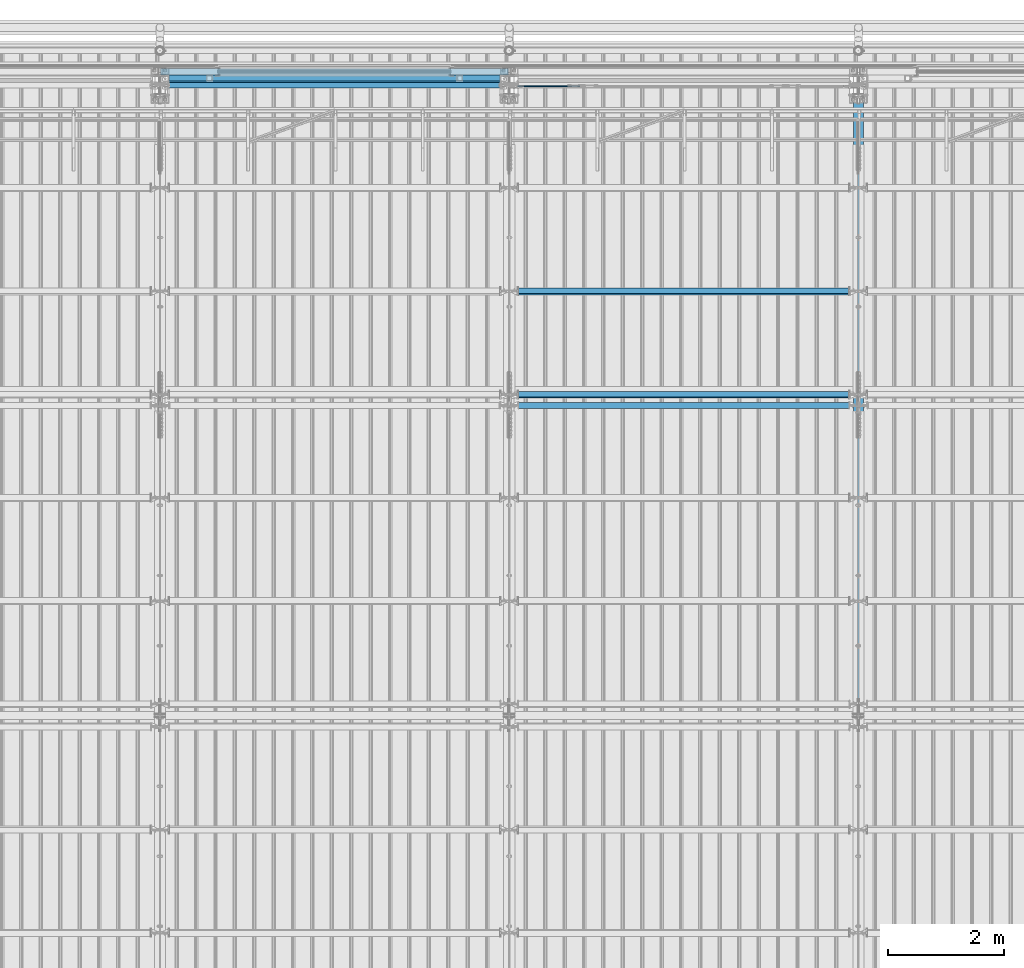
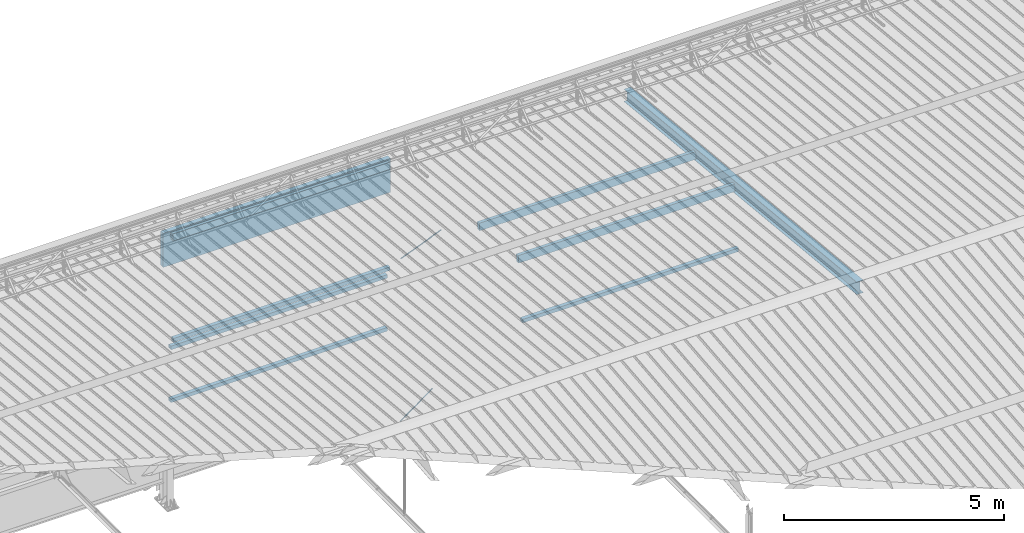
# One storey, part 268 of 709: 9 beams, 2 members, 2 openings, 11 elements without a shape of their own.
"""IFC4 building model written with IfcOpenShell, lengths in millimetres."""

from ifc_helpers import new_model, si_unit, direction, frame, origin_with_axes, place, context, subcontext, project, spatial, line, indexed_curve, outline, extrude, polygons, material, element, aggregate, save


model = new_model("IFC4")

# Units and contexts
model_context = context("Model", 3, precision=0.2, world=origin_with_axes(), true_north=direction((0.0, 1.0)))
body_context = subcontext(model_context, "Body", "Model", "MODEL_VIEW")
reference_context = subcontext(model_context, "Reference", "Model", "MODEL_VIEW")
ifc_project = project(units=[si_unit("LENGTHUNIT", "METRE", prefix="MILLI"), si_unit("AREAUNIT", "SQUARE_METRE"), si_unit("VOLUMEUNIT", "CUBIC_METRE"), si_unit("MASSUNIT", "GRAM", prefix="KILO"), si_unit("TIMEUNIT", "SECOND"), si_unit("PLANEANGLEUNIT", "RADIAN"), si_unit("SOLIDANGLEUNIT", "STERADIAN"), si_unit("THERMODYNAMICTEMPERATUREUNIT", "DEGREE_CELSIUS"), si_unit("LUMINOUSINTENSITYUNIT", "LUMEN")], contexts=[model_context])

# Site, building, storey
site_placement = place(None, origin_with_axes())
site = spatial("IfcSite", under=ifc_project, at=site_placement, CompositionType="ELEMENT")
building_placement = place(site_placement, origin_with_axes())
building = spatial("IfcBuilding", under=site, at=building_placement, Name="Undefined", CompositionType="ELEMENT")
storey_placement = place(building_placement, origin_with_axes())
storey = spatial("IfcBuildingStorey", under=building, at=storey_placement, Name="Undefined", CompositionType="ELEMENT", Elevation=0.0)

# Assembly, beam
assembly_1_placement = place(storey_placement, frame((28000.0, 21654.0, 7089.70002), z_axis=(-1.0, 0.0, 0.0), x_axis=(0.0, -0.9950371902, 0.099503719)))
assembly_1 = element("IfcElementAssembly", 1, at=assembly_1_placement, inside=storey)
ifc_material_1 = material(Name="C355-5", Category="STEEL")
beam_1_placement = place(assembly_1_placement, origin_with_axes())
beam_1 = element("IfcBeam", 2, at=beam_1_placement, material=ifc_material_1, ObjectType="432", context=body_context, shape_type="Tessellation", body=[
    polygons([(3.80474, -173.0, -87.0), (4.70474, -164.0, -87.0), (10665.6128, -164.0, -87.0), (10664.7128, -173.0, -87.0), (4.70474, -164.0, -3.0), (10665.6128, -164.0, -3.0), (37.50474, 164.0, -3.0), (10698.4128, 164.0, -3.0), (37.50474, 164.0, -87.0), (10698.4128, 164.0, -87.0), (38.40474, 173.0, -87.0), (10699.3128, 173.0, -87.0), (38.40474, 173.0, 87.0), (10699.3128, 173.0, 87.0), (37.50474, 164.0, 87.0), (10698.4128, 164.0, 87.0), (37.50474, 164.0, 3.0), (10698.4128, 164.0, 3.0), (4.70474, -164.0, 3.0), (10665.6128, -164.0, 3.0), (4.70474, -164.0, 87.0), (10665.6128, -164.0, 87.0), (3.80474, -173.0, 87.0), (10664.7128, -173.0, 87.0)], [[[1, 2, 3, 4]], [[2, 5, 6, 3]], [[5, 7, 8, 6]], [[7, 9, 10, 8]], [[9, 11, 12, 10]], [[11, 13, 14, 12]], [[13, 15, 16, 14]], [[15, 17, 18, 16]], [[17, 19, 20, 18]], [[19, 21, 22, 20]], [[21, 23, 24, 22]], [[23, 1, 4, 24]], [[6, 8, 10, 12, 14, 16, 18, 20, 22, 24, 4, 3]], [[23, 21, 19, 17, 15, 13, 11, 9, 7, 5, 2, 1]]], closed=True),
])
aggregate(assembly_1, [beam_1])

# Assembly, member, voiding feature
assembly_2_placement = place(storey_placement, frame((23129.07626, 21811.0, 672.76012), z_axis=(0.0, 1.0, 0.0), x_axis=(-0.8064830392, 0.0, -0.5912572261)))
assembly_2 = element("IfcElementAssembly", 3, at=assembly_2_placement, inside=storey)
member_1_placement = place(assembly_2_placement, origin_with_axes())
member_1 = element("IfcMember", 4, at=member_1_placement, material=ifc_material_1, ObjectType="548", context=body_context, shape_type="Tessellation", body=[
    polygons([(1225.82155, -5.0, 8.66025), (1225.82155, -7.07107, 7.07107), (1225.82155, -8.66025, 5.0), (1225.82155, -9.65926, 2.58819), (1225.82155, -10.0, 0.0), (1225.82155, -9.65926, -2.58819), (1225.82155, -8.66025, -5.0), (1225.82155, -7.07107, -7.07107), (1225.82155, -5.0, -8.66025), (1225.82155, -2.58819, -9.65926), (1225.82155, 0.0, -10.0), (1225.82155, 2.58819, -9.65926), (1225.82155, 5.0, -8.66025), (1225.82155, 7.07107, -7.07107), (1225.82155, 8.66025, -5.0), (1225.82155, 9.65926, -2.58819), (1225.82155, 10.0, 0.0), (1225.82155, 9.65926, 2.58819), (1225.82155, 8.66025, 5.0), (1225.82155, 7.07107, 7.07107), (1225.82155, 5.0, 8.66025), (1225.82155, 2.58819, 9.65926), (1225.82155, 0.0, 10.0), (1225.82155, -2.58819, 9.65926), (190.0, 10.0, 0.0), (190.0, 9.65926, 2.58819), (190.0, 8.66025, 5.0), (190.0, 7.07107, 7.07107), (190.0, 5.0, 8.66025), (190.0, 2.58819, 9.65926), (190.0, 0.0, 10.0), (190.0, -2.58819, 9.65926), (190.0, -5.0, 8.66025), (190.0, -7.07107, 7.07107), (190.0, -8.66025, 5.0), (190.0, -9.65926, 2.58819), (190.0, -10.0, 0.0), (190.0, -9.65926, -2.58819), (190.0, -8.66025, -5.0), (190.0, -7.07107, -7.07107), (190.0, -5.0, -8.66025), (190.0, -2.58819, -9.65926), (190.0, 0.0, -10.0), (190.0, 2.58819, -9.65926), (190.0, 5.0, -8.66025), (190.0, 7.07107, -7.07107), (190.0, 8.66025, -5.0), (190.0, 9.65926, -2.58819), (10.0, 7.36122, 4.25), (190.0, 7.36122, 4.25), (190.0, 8.21037, 2.19996), (10.0, 8.21037, 2.19996), (10.0, 6.01041, 6.01041), (190.0, 6.01041, 6.01041), (10.0, 4.25, 7.36122), (190.0, 4.25, 7.36122), (10.0, 2.19996, 8.21037), (190.0, 2.19996, 8.21037), (10.0, 0.0, 8.5), (190.0, 0.0, 8.5), (10.0, -2.19996, 8.21037), (190.0, -2.19996, 8.21037), (10.0, -4.25, 7.36122), (190.0, -4.25, 7.36122), (10.0, -6.01041, 6.01041), (190.0, -6.01041, 6.01041), (10.0, -7.36122, 4.25), (190.0, -7.36122, 4.25), (10.0, -8.21037, 2.19996), (190.0, -8.21037, 2.19996), (10.0, -8.5, 0.0), (190.0, -8.5, 0.0), (10.0, -8.21037, -2.19996), (190.0, -8.21037, -2.19996), (10.0, -7.36122, -4.25), (190.0, -7.36122, -4.25), (10.0, -6.01041, -6.01041), (190.0, -6.01041, -6.01041), (10.0, -4.25, -7.36122), (190.0, -4.25, -7.36122), (10.0, -2.19996, -8.21037), (190.0, -2.19996, -8.21037), (10.0, 0.0, -8.5), (190.0, 0.0, -8.5), (10.0, 2.19996, -8.21037), (190.0, 2.19996, -8.21037), (10.0, 4.25, -7.36122), (190.0, 4.25, -7.36122), (10.0, 6.01041, -6.01041), (190.0, 6.01041, -6.01041), (10.0, 7.36122, -4.25), (190.0, 7.36122, -4.25), (10.0, 8.21037, -2.19996), (190.0, 8.21037, -2.19996), (10.0, 8.5, 0.0), (190.0, 8.5, 0.0)], [[[1, 2, 3, 4, 5, 6, 7, 8, 9, 10, 11, 12, 13, 14, 15, 16, 17, 18, 19, 20, 21, 22, 23, 24]], [[18, 17, 25, 26]], [[19, 18, 26, 27]], [[20, 19, 27, 28]], [[21, 20, 28, 29]], [[22, 21, 29, 30]], [[23, 22, 30, 31]], [[24, 23, 31, 32]], [[1, 24, 32, 33]], [[2, 1, 33, 34]], [[3, 2, 34, 35]], [[4, 3, 35, 36]], [[5, 4, 36, 37]], [[6, 5, 37, 38]], [[7, 6, 38, 39]], [[8, 7, 39, 40]], [[9, 8, 40, 41]], [[10, 9, 41, 42]], [[11, 10, 42, 43]], [[12, 11, 43, 44]], [[13, 12, 44, 45]], [[14, 13, 45, 46]], [[15, 14, 46, 47]], [[16, 15, 47, 48]], [[17, 16, 48, 25]], [[25, 48, 47, 46, 45, 44, 43, 42, 41, 40, 39, 38, 37, 36, 35, 34, 33, 32, 31, 30, 29, 28, 27, 26], [74, 76, 78, 80, 82, 84, 86, 88, 90, 92, 94, 96, 51, 50, 54, 56, 58, 60, 62, 64, 66, 68, 70, 72]], [[49, 50, 51, 52]], [[53, 54, 50, 49]], [[55, 56, 54, 53]], [[57, 58, 56, 55]], [[59, 60, 58, 57]], [[61, 62, 60, 59]], [[63, 64, 62, 61]], [[65, 66, 64, 63]], [[67, 68, 66, 65]], [[69, 70, 68, 67]], [[71, 72, 70, 69]], [[73, 74, 72, 71]], [[75, 76, 74, 73]], [[77, 78, 76, 75]], [[79, 80, 78, 77]], [[81, 82, 80, 79]], [[83, 84, 82, 81]], [[85, 86, 84, 83]], [[87, 88, 86, 85]], [[89, 90, 88, 87]], [[91, 92, 90, 89]], [[93, 94, 92, 91]], [[95, 96, 94, 93]], [[52, 51, 96, 95]], [[91, 89, 87, 85, 83, 81, 79, 77, 75, 73, 71, 69, 67, 65, 63, 61, 59, 57, 55, 53, 49, 52, 95, 93]]], closed=True),
])
voiding_feature_1_placement = place(member_1_placement, frame((10.0, 0.0, 0.0), z_axis=(0.0, -1.0, 0.0), x_axis=(1.0, 0.0, 0.0)))
element("IfcVoidingFeature", 5, at=voiding_feature_1_placement, cuts=member_1, PredefinedType="HOLE", context=reference_context, identifier="Reference", shape_type="SolidModel", body=[
    extrude(outline(indexed_curve([(10.5, 0.0), (10.14222, 2.7176), (9.09327, 5.25), (7.42462, 7.42462), (5.25, 9.09327), (2.7176, 10.14222), (0.0, 10.5), (-2.7176, 10.14222), (-5.25, 9.09327), (-7.42462, 7.42462), (-9.09327, 5.25), (-10.14222, 2.7176), (-10.5, 0.0), (-10.14222, -2.7176), (-9.09327, -5.25), (-7.42462, -7.42462), (-5.25, -9.09327), (-2.7176, -10.14222), (0.0, -10.5), (2.7176, -10.14222), (5.25, -9.09327), (7.42462, -7.42462), (9.09327, -5.25), (10.14222, -2.7176)], segments=[line(1, 2, 3, 4, 5, 6, 7, 8, 9, 10, 11, 12, 13, 14, 15, 16, 17, 18, 19, 20, 21, 22, 23, 24, 1)])), frame((0.0, 0.0, 0.0), z_axis=(-1.0, 0.0, 0.0), x_axis=(0.0, 0.0, 1.0)), (0.0, 0.0, -1.0), 180.0),
])
aggregate(assembly_2, [member_1])

assembly_3_placement = place(storey_placement, frame((23387.0491, 21811.0, 4959.49238), z_axis=(0.0, 1.0, 0.0), x_axis=(-0.9286065, 0.0, -0.371065989)))
assembly_3 = element("IfcElementAssembly", 6, at=assembly_3_placement, inside=storey)
member_2_placement = place(assembly_3_placement, origin_with_axes())
member_2 = element("IfcMember", 7, at=member_2_placement, material=ifc_material_1, ObjectType="515", context=body_context, shape_type="Tessellation", body=[
    polygons([(1330.0, -5.0, 8.66025), (1330.0, -7.07107, 7.07107), (1330.0, -8.66025, 5.0), (1330.0, -9.65926, 2.58819), (1330.0, -10.0, 0.0), (1330.0, -9.65926, -2.58819), (1330.0, -8.66025, -5.0), (1330.0, -7.07107, -7.07107), (1330.0, -5.0, -8.66025), (1330.0, -2.58819, -9.65926), (1330.0, 0.0, -10.0), (1330.0, 2.58819, -9.65926), (1330.0, 5.0, -8.66025), (1330.0, 7.07107, -7.07107), (1330.0, 8.66025, -5.0), (1330.0, 9.65926, -2.58819), (1330.0, 10.0, 0.0), (1330.0, 9.65926, 2.58819), (1330.0, 8.66025, 5.0), (1330.0, 7.07107, 7.07107), (1330.0, 5.0, 8.66025), (1330.0, 2.58819, 9.65926), (1330.0, 0.0, 10.0), (1330.0, -2.58819, 9.65926), (190.0, 10.0, 0.0), (190.0, 9.65926, 2.58819), (190.0, 8.66025, 5.0), (190.0, 7.07107, 7.07107), (190.0, 5.0, 8.66025), (190.0, 2.58819, 9.65926), (190.0, 0.0, 10.0), (190.0, -2.58819, 9.65926), (190.0, -5.0, 8.66025), (190.0, -7.07107, 7.07107), (190.0, -8.66025, 5.0), (190.0, -9.65926, 2.58819), (190.0, -10.0, 0.0), (190.0, -9.65926, -2.58819), (190.0, -8.66025, -5.0), (190.0, -7.07107, -7.07107), (190.0, -5.0, -8.66025), (190.0, -2.58819, -9.65926), (190.0, 0.0, -10.0), (190.0, 2.58819, -9.65926), (190.0, 5.0, -8.66025), (190.0, 7.07107, -7.07107), (190.0, 8.66025, -5.0), (190.0, 9.65926, -2.58819), (10.0, 7.36122, 4.25), (190.0, 7.36122, 4.25), (190.0, 8.21037, 2.19996), (10.0, 8.21037, 2.19996), (10.0, 6.01041, 6.01041), (190.0, 6.01041, 6.01041), (10.0, 4.25, 7.36122), (190.0, 4.25, 7.36122), (10.0, 2.19996, 8.21037), (190.0, 2.19996, 8.21037), (10.0, 0.0, 8.5), (190.0, 0.0, 8.5), (10.0, -2.19996, 8.21037), (190.0, -2.19996, 8.21037), (10.0, -4.25, 7.36122), (190.0, -4.25, 7.36122), (10.0, -6.01041, 6.01041), (190.0, -6.01041, 6.01041), (10.0, -7.36122, 4.25), (190.0, -7.36122, 4.25), (10.0, -8.21037, 2.19996), (190.0, -8.21037, 2.19996), (10.0, -8.5, 0.0), (190.0, -8.5, 0.0), (10.0, -8.21037, -2.19996), (190.0, -8.21037, -2.19996), (10.0, -7.36122, -4.25), (190.0, -7.36122, -4.25), (10.0, -6.01041, -6.01041), (190.0, -6.01041, -6.01041), (10.0, -4.25, -7.36122), (190.0, -4.25, -7.36122), (10.0, -2.19996, -8.21037), (190.0, -2.19996, -8.21037), (10.0, 0.0, -8.5), (190.0, 0.0, -8.5), (10.0, 2.19996, -8.21037), (190.0, 2.19996, -8.21037), (10.0, 4.25, -7.36122), (190.0, 4.25, -7.36122), (10.0, 6.01041, -6.01041), (190.0, 6.01041, -6.01041), (10.0, 7.36122, -4.25), (190.0, 7.36122, -4.25), (10.0, 8.21037, -2.19996), (190.0, 8.21037, -2.19996), (10.0, 8.5, 0.0), (190.0, 8.5, 0.0)], [[[1, 2, 3, 4, 5, 6, 7, 8, 9, 10, 11, 12, 13, 14, 15, 16, 17, 18, 19, 20, 21, 22, 23, 24]], [[18, 17, 25, 26]], [[19, 18, 26, 27]], [[20, 19, 27, 28]], [[21, 20, 28, 29]], [[22, 21, 29, 30]], [[23, 22, 30, 31]], [[24, 23, 31, 32]], [[1, 24, 32, 33]], [[2, 1, 33, 34]], [[3, 2, 34, 35]], [[4, 3, 35, 36]], [[5, 4, 36, 37]], [[6, 5, 37, 38]], [[7, 6, 38, 39]], [[8, 7, 39, 40]], [[9, 8, 40, 41]], [[10, 9, 41, 42]], [[11, 10, 42, 43]], [[12, 11, 43, 44]], [[13, 12, 44, 45]], [[14, 13, 45, 46]], [[15, 14, 46, 47]], [[16, 15, 47, 48]], [[17, 16, 48, 25]], [[25, 48, 47, 46, 45, 44, 43, 42, 41, 40, 39, 38, 37, 36, 35, 34, 33, 32, 31, 30, 29, 28, 27, 26], [74, 76, 78, 80, 82, 84, 86, 88, 90, 92, 94, 96, 51, 50, 54, 56, 58, 60, 62, 64, 66, 68, 70, 72]], [[49, 50, 51, 52]], [[53, 54, 50, 49]], [[55, 56, 54, 53]], [[57, 58, 56, 55]], [[59, 60, 58, 57]], [[61, 62, 60, 59]], [[63, 64, 62, 61]], [[65, 66, 64, 63]], [[67, 68, 66, 65]], [[69, 70, 68, 67]], [[71, 72, 70, 69]], [[73, 74, 72, 71]], [[75, 76, 74, 73]], [[77, 78, 76, 75]], [[79, 80, 78, 77]], [[81, 82, 80, 79]], [[83, 84, 82, 81]], [[85, 86, 84, 83]], [[87, 88, 86, 85]], [[89, 90, 88, 87]], [[91, 92, 90, 89]], [[93, 94, 92, 91]], [[95, 96, 94, 93]], [[52, 51, 96, 95]], [[91, 89, 87, 85, 83, 81, 79, 77, 75, 73, 71, 69, 67, 65, 63, 61, 59, 57, 55, 53, 49, 52, 95, 93]]], closed=True),
])
voiding_feature_2_placement = place(member_2_placement, frame((10.0, 0.0, 0.0), z_axis=(0.0, -1.0, 0.0), x_axis=(1.0, 0.0, 0.0)))
element("IfcVoidingFeature", 8, at=voiding_feature_2_placement, cuts=member_2, PredefinedType="HOLE", context=reference_context, identifier="Reference", shape_type="SolidModel", body=[
    extrude(outline(indexed_curve([(10.5, 0.0), (10.14222, 2.7176), (9.09327, 5.25), (7.42462, 7.42462), (5.25, 9.09327), (2.7176, 10.14222), (0.0, 10.5), (-2.7176, 10.14222), (-5.25, 9.09327), (-7.42462, 7.42462), (-9.09327, 5.25), (-10.14222, 2.7176), (-10.5, 0.0), (-10.14222, -2.7176), (-9.09327, -5.25), (-7.42462, -7.42462), (-5.25, -9.09327), (-2.7176, -10.14222), (0.0, -10.5), (2.7176, -10.14222), (5.25, -9.09327), (7.42462, -7.42462), (9.09327, -5.25), (10.14222, -2.7176)], segments=[line(1, 2, 3, 4, 5, 6, 7, 8, 9, 10, 11, 12, 13, 14, 15, 16, 17, 18, 19, 20, 21, 22, 23, 24, 1)])), frame((0.0, 0.0, 0.0), z_axis=(-1.0, 0.0, 0.0), x_axis=(0.0, 0.0, 1.0)), (0.0, 0.0, -1.0), 180.0),
])
aggregate(assembly_3, [member_2])

# Assembly, beam
assembly_4_placement = place(storey_placement, frame((22000.0, 21950.0, 2550.0), z_axis=(0.0, 0.0, -1.0), x_axis=(-1.0, 0.0, 0.0)))
assembly_4 = element("IfcElementAssembly", 9, at=assembly_4_placement, inside=storey)
ifc_material_2 = material(Name="C355", Category="STEEL")
beam_2_placement = place(assembly_4_placement, origin_with_axes())
beam_2 = element("IfcBeam", 10, at=beam_2_placement, material=ifc_material_2, ObjectType="545", context=body_context, shape_type="Tessellation", body=[
    polygons([(155.0, -47.0, -47.0), (155.0, -47.0, 47.0), (5845.0, -47.0, 47.0), (5845.0, -47.0, -47.0), (155.0, 47.0, 47.0), (5845.0, 47.0, 47.0), (155.0, 47.0, -47.0), (5845.0, 47.0, -47.0), (155.0, -50.0, -50.0), (155.0, 50.0, -50.0), (5845.0, 50.0, -50.0), (5845.0, -50.0, -50.0), (155.0, 50.0, 50.0), (5845.0, 50.0, 50.0), (155.0, -50.0, 50.0), (5845.0, -50.0, 50.0)], [[[1, 2, 3, 4]], [[2, 5, 6, 3]], [[5, 7, 8, 6]], [[7, 1, 4, 8]], [[9, 10, 11, 12]], [[10, 13, 14, 11]], [[13, 15, 16, 14]], [[15, 9, 12, 16]], [[14, 16, 12, 11], [6, 8, 4, 3]], [[15, 13, 10, 9], [7, 5, 2, 1]]], closed=True),
])
aggregate(assembly_4, [beam_2])

assembly_5_placement = place(storey_placement, frame((22000.0, 21950.0, 4020.0), z_axis=(0.0, 0.0, -1.0), x_axis=(-1.0, 0.0, 0.0)))
assembly_5 = element("IfcElementAssembly", 11, at=assembly_5_placement, inside=storey)
beam_3_placement = place(assembly_5_placement, origin_with_axes())
beam_3 = element("IfcBeam", 12, at=beam_3_placement, material=ifc_material_2, ObjectType="545", context=body_context, shape_type="Tessellation", body=[
    polygons([(155.0, -47.0, -47.0), (155.0, -47.0, 47.0), (5845.0, -47.0, 47.0), (5845.0, -47.0, -47.0), (155.0, 47.0, 47.0), (5845.0, 47.0, 47.0), (155.0, 47.0, -47.0), (5845.0, 47.0, -47.0), (155.0, -50.0, -50.0), (155.0, 50.0, -50.0), (5845.0, 50.0, -50.0), (5845.0, -50.0, -50.0), (155.0, 50.0, 50.0), (5845.0, 50.0, 50.0), (155.0, -50.0, 50.0), (5845.0, -50.0, 50.0)], [[[1, 2, 3, 4]], [[2, 5, 6, 3]], [[5, 7, 8, 6]], [[7, 1, 4, 8]], [[9, 10, 11, 12]], [[10, 13, 14, 11]], [[13, 15, 16, 14]], [[15, 9, 12, 16]], [[14, 16, 12, 11], [6, 8, 4, 3]], [[15, 13, 10, 9], [7, 5, 2, 1]]], closed=True),
])
aggregate(assembly_5, [beam_3])

assembly_6_placement = place(storey_placement, frame((22000.0, 21827.0, 4310.0), z_axis=(0.0, 0.0, -1.0), x_axis=(-1.0, 0.0, 0.0)))
assembly_6 = element("IfcElementAssembly", 13, at=assembly_6_placement, inside=storey)
beam_4_placement = place(assembly_6_placement, origin_with_axes())
beam_4 = element("IfcBeam", 14, at=beam_4_placement, material=ifc_material_2, ObjectType="546", context=body_context, shape_type="Tessellation", body=[
    polygons([(155.0, -47.0, -47.0), (155.0, -47.0, 47.0), (5845.0, -47.0, 47.0), (5845.0, -47.0, -47.0), (155.0, 47.0, 47.0), (5845.0, 47.0, 47.0), (155.0, 47.0, -47.0), (5845.0, 47.0, -47.0), (155.0, -50.0, -50.0), (155.0, 50.0, -50.0), (5845.0, 50.0, -50.0), (5845.0, -50.0, -50.0), (155.0, 50.0, 50.0), (5845.0, 50.0, 50.0), (155.0, -50.0, 50.0), (5845.0, -50.0, 50.0)], [[[1, 2, 3, 4]], [[2, 5, 6, 3]], [[5, 7, 8, 6]], [[7, 1, 4, 8]], [[9, 10, 11, 12]], [[10, 13, 14, 11]], [[13, 15, 16, 14]], [[15, 9, 12, 16]], [[14, 16, 12, 11], [6, 8, 4, 3]], [[15, 13, 10, 9], [7, 5, 2, 1]]], closed=True),
])
aggregate(assembly_6, [beam_4])

assembly_7_placement = place(storey_placement, frame((22000.0, 16327.0, 6074.30002), z_axis=(0.0, -1.0, 0.0), x_axis=(1.0, 0.0, 0.0)))
assembly_7 = element("IfcElementAssembly", 15, at=assembly_7_placement, inside=storey)
beam_5_placement = place(assembly_7_placement, origin_with_axes())
beam_5 = element("IfcBeam", 16, at=beam_5_placement, material=ifc_material_2, ObjectType="557", context=body_context, shape_type="Tessellation", body=[
    polygons([(162.0, -47.0, -47.0), (162.0, -47.0, 47.0), (5838.0, -47.0, 47.0), (5838.0, -47.0, -47.0), (162.0, 47.0, 47.0), (5838.0, 47.0, 47.0), (162.0, 47.0, -47.0), (5838.0, 47.0, -47.0), (162.0, -50.0, -50.0), (162.0, 50.0, -50.0), (5838.0, 50.0, -50.0), (5838.0, -50.0, -50.0), (162.0, 50.0, 50.0), (5838.0, 50.0, 50.0), (162.0, -50.0, 50.0), (5838.0, -50.0, 50.0)], [[[1, 2, 3, 4]], [[2, 5, 6, 3]], [[5, 7, 8, 6]], [[7, 1, 4, 8]], [[9, 10, 11, 12]], [[10, 13, 14, 11]], [[13, 15, 16, 14]], [[15, 9, 12, 16]], [[14, 16, 12, 11], [6, 8, 4, 3]], [[15, 13, 10, 9], [7, 5, 2, 1]]], closed=True),
])
aggregate(assembly_7, [beam_5])

assembly_8_placement = place(storey_placement, frame((22000.0, 21841.04467, 7154.40952), z_axis=(0.0, -0.9950371902, 0.099503719), x_axis=(-1.0, 0.0, 0.0)))
assembly_8 = element("IfcElementAssembly", 17, at=assembly_8_placement, inside=storey)
beam_6_placement = place(assembly_8_placement, origin_with_axes())
beam_6 = element("IfcBeam", 18, at=beam_6_placement, material=ifc_material_2, ObjectType="578", context=body_context, shape_type="Tessellation", body=[
    polygons([(145.0, -86.0, -46.0), (145.0, -86.0, 46.0), (5855.0, -86.0, 46.0), (5855.0, -86.0, -46.0), (145.0, 86.0, 46.0), (5855.0, 86.0, 46.0), (145.0, 86.0, -46.0), (5855.0, 86.0, -46.0), (145.0, -90.0, -50.0), (145.0, 90.0, -50.0), (5855.0, 90.0, -50.0), (5855.0, -90.0, -50.0), (145.0, 90.0, 50.0), (5855.0, 90.0, 50.0), (145.0, -90.0, 50.0), (5855.0, -90.0, 50.0)], [[[1, 2, 3, 4]], [[2, 5, 6, 3]], [[5, 7, 8, 6]], [[7, 1, 4, 8]], [[9, 10, 11, 12]], [[10, 13, 14, 11]], [[13, 15, 16, 14]], [[15, 9, 12, 16]], [[14, 16, 12, 11], [6, 8, 4, 3]], [[15, 13, 10, 9], [7, 5, 2, 1]]], closed=True),
])
aggregate(assembly_8, [beam_6])

assembly_9_placement = place(storey_placement, frame((28000.0, 16509.95037, 7677.46908), z_axis=(0.0, -0.9950371902, 0.099503719), x_axis=(-1.0, 0.0, 0.0)))
assembly_9 = element("IfcElementAssembly", 19, at=assembly_9_placement, inside=storey)
beam_7_placement = place(assembly_9_placement, origin_with_axes())
beam_7 = element("IfcBeam", 20, at=beam_7_placement, material=ifc_material_2, ObjectType="579", context=body_context, shape_type="Tessellation", body=[
    polygons([(155.0, -96.0, -46.0), (155.0, -96.0, 46.0), (5845.0, -96.0, 46.0), (5845.0, -96.0, -46.0), (155.0, 96.0, 46.0), (5845.0, 96.0, 46.0), (155.0, 96.0, -46.0), (5845.0, 96.0, -46.0), (155.0, -100.0, -50.0), (155.0, 100.0, -50.0), (5845.0, 100.0, -50.0), (5845.0, -100.0, -50.0), (155.0, 100.0, 50.0), (5845.0, 100.0, 50.0), (155.0, -100.0, 50.0), (5845.0, -100.0, 50.0)], [[[1, 2, 3, 4]], [[2, 5, 6, 3]], [[5, 7, 8, 6]], [[7, 1, 4, 8]], [[9, 10, 11, 12]], [[10, 13, 14, 11]], [[13, 15, 16, 14]], [[15, 9, 12, 16]], [[14, 16, 12, 11], [6, 8, 4, 3]], [[15, 13, 10, 9], [7, 5, 2, 1]]], closed=True),
])
aggregate(assembly_9, [beam_7])

assembly_10_placement = place(storey_placement, frame((28000.0, 18286.65012, 7499.7991), z_axis=(0.0, -0.9950371902, 0.099503719), x_axis=(-1.0, 0.0, 0.0)))
assembly_10 = element("IfcElementAssembly", 21, at=assembly_10_placement, inside=storey)
beam_8_placement = place(assembly_10_placement, origin_with_axes())
beam_8 = element("IfcBeam", 22, at=beam_8_placement, material=ifc_material_2, ObjectType="579", context=body_context, shape_type="Tessellation", body=[
    polygons([(155.0, -96.0, -46.0), (155.0, -96.0, 46.0), (5845.0, -96.0, 46.0), (5845.0, -96.0, -46.0), (155.0, 96.0, 46.0), (5845.0, 96.0, 46.0), (155.0, 96.0, -46.0), (5845.0, 96.0, -46.0), (155.0, -100.0, -50.0), (155.0, 100.0, -50.0), (5845.0, 100.0, -50.0), (5845.0, -100.0, -50.0), (155.0, 100.0, 50.0), (5845.0, 100.0, 50.0), (155.0, -100.0, 50.0), (5845.0, -100.0, 50.0)], [[[1, 2, 3, 4]], [[2, 5, 6, 3]], [[5, 7, 8, 6]], [[7, 1, 4, 8]], [[9, 10, 11, 12]], [[10, 13, 14, 11]], [[13, 15, 16, 14]], [[15, 9, 12, 16]], [[14, 16, 12, 11], [6, 8, 4, 3]], [[15, 13, 10, 9], [7, 5, 2, 1]]], closed=True),
])
aggregate(assembly_10, [beam_8])

assembly_11_placement = place(storey_placement, frame((16010.0, 22060.0, 6845.0), z_axis=(0.0, 0.0, -1.0), x_axis=(1.0, 0.0, 0.0)))
assembly_11 = element("IfcElementAssembly", 23, at=assembly_11_placement, inside=storey)
ifc_material_3 = material(Name="Insulation", Category="Insulation")
beam_9_placement = place(assembly_11_placement, origin_with_axes())
beam_9 = element("IfcBeam", 24, at=beam_9_placement, material=ifc_material_3, ObjectType="P-108", context=body_context, shape_type="Tessellation", body=[
    polygons([(0.0, 60.0, 595.0), (0.0, -60.0, 595.0), (5980.0, -60.0, 595.0), (5980.0, 60.0, 595.0), (5980.0, 60.0, -351.923), (0.0, 60.0, -351.923), (0.0, -60.0, -351.923), (5980.0, -60.0, -351.923)], [[[1, 2, 3, 4]], [[1, 4, 5, 6]], [[2, 1, 6, 7]], [[3, 2, 7, 8]], [[4, 3, 8, 5]], [[7, 6, 5, 8]]], closed=True),
])
aggregate(assembly_11, [beam_9])

save(model, "model.ifc")
